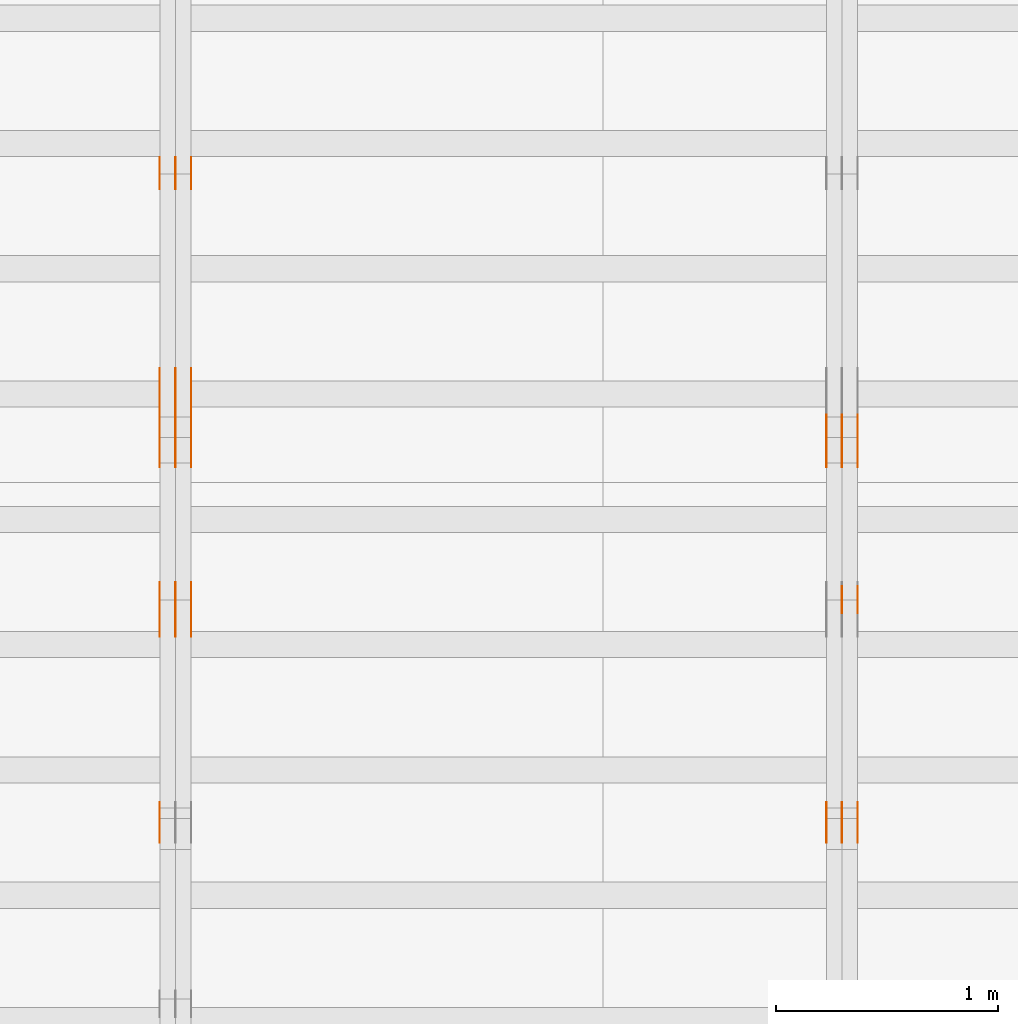
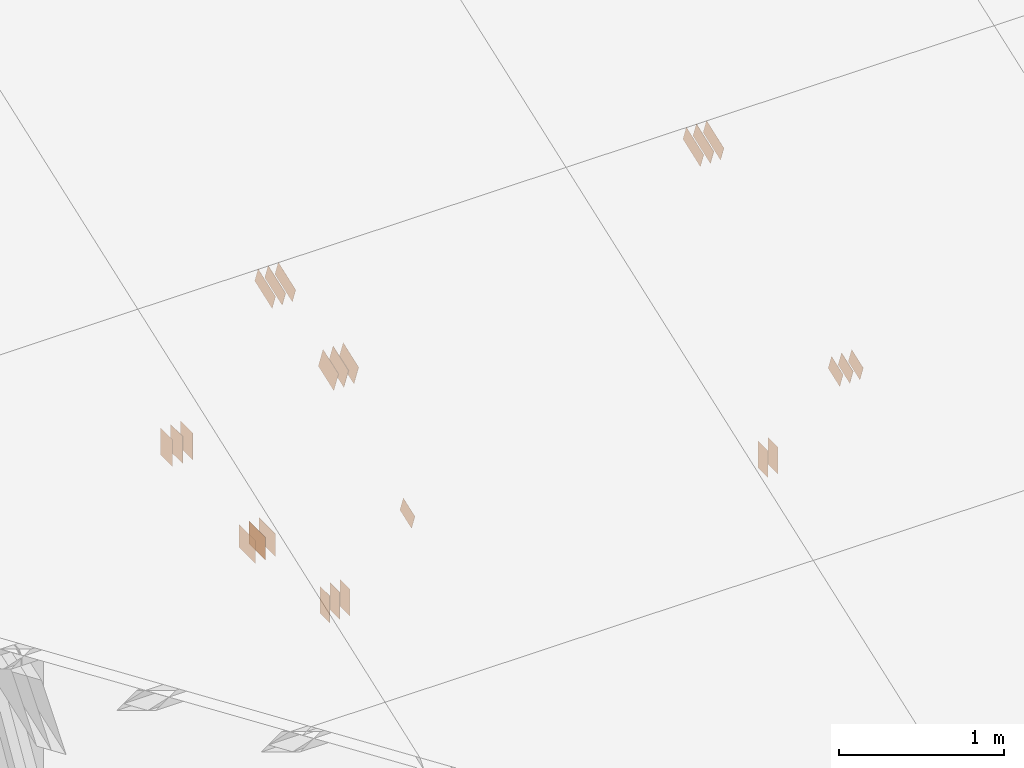
# One storey, part 138 of 189: 31 proxies.
"""IFC2X3 building model written with IfcOpenShell, lengths in millimetres."""

from ifc_helpers import new_model, entity, si_unit, converted_unit, derived_unit, direction, frame, frame_2d, origin, origin_2d_with_axis, place, context, subcontext, project, spatial, polyline, rectangle, outline, extrude, source, transform, mapped, material, type_object, type_shapes, element, save


model = new_model("IFC2X3")

# Units and contexts
model_context = context("Model", 3, precision=0.01, world=origin(), true_north=direction((6.12303176911189e-17, 1.0)))
body_context = subcontext(model_context, "Body", "Model", "MODEL_VIEW")
ifc_project = project(units=[si_unit("LENGTHUNIT", "METRE", prefix="MILLI"), si_unit("AREAUNIT", "SQUARE_METRE"), si_unit("VOLUMEUNIT", "CUBIC_METRE"), converted_unit("PLANEANGLEUNIT", "DEGREE", entity("IfcRatioMeasure", 0.0174532925199433), si_unit("PLANEANGLEUNIT", "RADIAN"), dimensions=[0, 0, 0, 0, 0, 0, 0]), si_unit("MASSUNIT", "GRAM", prefix="KILO"), derived_unit("MASSDENSITYUNIT", [(si_unit("MASSUNIT", "GRAM", prefix="KILO"), 1), (si_unit("LENGTHUNIT", "METRE"), -3)]), si_unit("TIMEUNIT", "SECOND"), si_unit("FREQUENCYUNIT", "HERTZ"), si_unit("THERMODYNAMICTEMPERATUREUNIT", "DEGREE_CELSIUS"), derived_unit("THERMALTRANSMITTANCEUNIT", [(si_unit("MASSUNIT", "GRAM", prefix="KILO"), 1), (si_unit("THERMODYNAMICTEMPERATUREUNIT", "KELVIN"), -1), (si_unit("TIMEUNIT", "SECOND"), -3)]), derived_unit("VOLUMETRICFLOWRATEUNIT", [(si_unit("LENGTHUNIT", "METRE"), 3), (si_unit("TIMEUNIT", "SECOND"), -1)]), si_unit("ELECTRICCURRENTUNIT", "AMPERE"), si_unit("ELECTRICVOLTAGEUNIT", "VOLT"), si_unit("POWERUNIT", "WATT"), si_unit("FORCEUNIT", "NEWTON"), si_unit("ILLUMINANCEUNIT", "LUX"), si_unit("LUMINOUSFLUXUNIT", "LUMEN"), si_unit("LUMINOUSINTENSITYUNIT", "CANDELA"), derived_unit("USERDEFINED", [(si_unit("MASSUNIT", "GRAM", prefix="KILO"), -1), (si_unit("LENGTHUNIT", "METRE"), -2), (si_unit("TIMEUNIT", "SECOND"), 3), (si_unit("LUMINOUSFLUXUNIT", "LUMEN"), 1)]), derived_unit("LINEARVELOCITYUNIT", [(si_unit("LENGTHUNIT", "METRE"), 1), (si_unit("TIMEUNIT", "SECOND"), -1)]), si_unit("PRESSUREUNIT", "PASCAL"), derived_unit("USERDEFINED", [(si_unit("LENGTHUNIT", "METRE"), -2), (si_unit("MASSUNIT", "GRAM", prefix="KILO"), 1), (si_unit("TIMEUNIT", "SECOND"), -2)])], contexts=[model_context])

# Site, building, storey
site_placement = place(None, origin())
site = spatial("IfcSite", under=ifc_project, at=site_placement, CompositionType="ELEMENT")
building_placement = place(site_placement, origin())
building = spatial("IfcBuilding", under=site, at=building_placement, CompositionType="ELEMENT")
storey_placement = place(building_placement, origin())
storey = spatial("IfcBuildingStorey", under=building, at=storey_placement, Name="Default", CompositionType="ELEMENT", Elevation=0.0)

# Proxies
ifc_material_1 = material(Name="IfcSurfaceStyle #201446")
building_element_proxy_type_1 = type_object("IfcBuildingElementProxyType", PredefinedType="NOTDEFINED", material=ifc_material_1)
shared_shape_1 = source(origin(), body_context, "Body", "SweptSolid", [
    extrude(outline(polyline([(-112.500654374667, -59.9999021691247), (112.500117969231, -59.9999021691247), (112.500612624162, 59.9999021691247), (-112.500076218726, 59.9999021691247), (-112.500654374667, -59.9999021691247)])), frame((112.500612624162, 60.0003514046321, 0.0), z_axis=(0.0, 0.0, 1.0), x_axis=(-1.0, 0.0, 0.0)), (0.0, 0.0, 1.0), 1.3),
])
type_shapes(building_element_proxy_type_1, [shared_shape_1])
proxy_1_placement = place(building_placement, frame((36301.3, 5418.0703125, 2162.37353515625), z_axis=(-1.0, 0.0, 0.0), x_axis=(0.0, 0.939692620785908, 0.342020143325669)))
element("IfcBuildingElementProxy", 1, at=proxy_1_placement, inside=storey, type_object=building_element_proxy_type_1, material=ifc_material_1, context=body_context, shape_type="MappedRepresentation", body=[
    mapped(shared_shape_1, transform((0.0, 0.0, 0.0), scale=1.0)),
])
ifc_material_2 = material(Name="IfcSurfaceStyle #201389")
building_element_proxy_type_2 = type_object("IfcBuildingElementProxyType", PredefinedType="NOTDEFINED", material=ifc_material_2)
shared_shape_2 = source(origin(), body_context, "Body", "SweptSolid", [
    extrude(outline(polyline([(-112.500654374667, -59.9999021691247), (112.500117969231, -59.9999021691247), (112.500612624162, 59.9999021691247), (-112.500076218726, 59.9999021691247), (-112.500654374667, -59.9999021691247)])), frame((112.500612624162, 60.0003514046321, 0.0), z_axis=(0.0, 0.0, 1.0), x_axis=(-1.0, 0.0, 0.0)), (0.0, 0.0, 1.0), 1.29999999999998),
])
type_shapes(building_element_proxy_type_2, [shared_shape_2])
proxy_2_placement = place(building_placement, frame((36230.0, 5418.0703125, 2162.37353515625), z_axis=(-1.0, 0.0, 0.0), x_axis=(0.0, 0.939692620785908, 0.342020143325669)))
element("IfcBuildingElementProxy", 2, at=proxy_2_placement, inside=storey, type_object=building_element_proxy_type_2, material=ifc_material_2, context=body_context, shape_type="MappedRepresentation", body=[
    mapped(shared_shape_2, transform((0.0, 0.0, 0.0), scale=1.0)),
])
ifc_material_3 = material(Name="IfcSurfaceStyle #201332")
building_element_proxy_type_3 = type_object("IfcBuildingElementProxyType", PredefinedType="NOTDEFINED", material=ifc_material_3)
shared_shape_3 = source(origin(), body_context, "Body", "SweptSolid", [
    extrude(outline(polyline([(-112.500654374667, -59.9999021691247), (112.500117969231, -59.9999021691247), (112.500612624162, 59.9999021691247), (-112.500076218726, 59.9999021691247), (-112.500654374667, -59.9999021691247)])), frame((112.500612624162, 60.0003514046321, 0.0), z_axis=(0.0, 0.0, 1.0), x_axis=(-1.0, 0.0, 0.0)), (0.0, 0.0, 1.0), 1.29999999999998),
])
type_shapes(building_element_proxy_type_3, [shared_shape_3])
proxy_3_placement = place(building_placement, frame((36231.3, 5418.0703125, 2162.37353515625), z_axis=(-1.0, 0.0, 0.0), x_axis=(0.0, 0.939692620785908, 0.342020143325669)))
element("IfcBuildingElementProxy", 3, at=proxy_3_placement, inside=storey, type_object=building_element_proxy_type_3, material=ifc_material_3, context=body_context, shape_type="MappedRepresentation", body=[
    mapped(shared_shape_3, transform((0.0, 0.0, 0.0), scale=1.0)),
])
ifc_material_4 = material(Name="IfcSurfaceStyle #201275")
building_element_proxy_type_4 = type_object("IfcBuildingElementProxyType", PredefinedType="NOTDEFINED", material=ifc_material_4)
shared_shape_4 = source(origin(), body_context, "Body", "SweptSolid", [
    extrude(outline(polyline([(-112.500654374667, -59.9999021691247), (112.500117969231, -59.9999021691247), (112.500612624162, 59.9999021691247), (-112.500076218726, 59.9999021691247), (-112.500654374667, -59.9999021691247)])), frame((112.500612624162, 60.0003514046321, 0.0), z_axis=(0.0, 0.0, 1.0), x_axis=(-1.0, 0.0, 0.0)), (0.0, 0.0, 1.0), 1.29999999999999),
])
type_shapes(building_element_proxy_type_4, [shared_shape_4])
proxy_4_placement = place(building_placement, frame((36160.0, 5418.0703125, 2162.37353515625), z_axis=(-1.0, 0.0, 0.0), x_axis=(0.0, 0.939692620785908, 0.342020143325669)))
element("IfcBuildingElementProxy", 4, at=proxy_4_placement, inside=storey, type_object=building_element_proxy_type_4, material=ifc_material_4, context=body_context, shape_type="MappedRepresentation", body=[
    mapped(shared_shape_4, transform((0.0, 0.0, 0.0), scale=1.0)),
])
ifc_material_5 = material(Name="IfcSurfaceStyle #200762")
building_element_proxy_type_5 = type_object("IfcBuildingElementProxyType", PredefinedType="NOTDEFINED", material=ifc_material_5)
shared_shape_5 = source(origin(), body_context, "Body", "SweptSolid", [
    extrude(rectangle(XDim=200.0, YDim=120.0, at=origin_2d_with_axis()), frame((100.0, 60.0, 0.0), z_axis=(0.0, 0.0, 1.0), x_axis=(-1.0, 0.0, 0.0)), (0.0, 0.0, 1.0), 1.3),
])
type_shapes(building_element_proxy_type_5, [shared_shape_5])
proxy_5_placement = place(building_placement, frame((36301.3, 4760.65625, 145.0), z_axis=(-1.0, 0.0, 0.0), x_axis=(0.0, 0.0, 1.0)))
element("IfcBuildingElementProxy", 5, at=proxy_5_placement, inside=storey, type_object=building_element_proxy_type_5, material=ifc_material_5, context=body_context, shape_type="MappedRepresentation", body=[
    mapped(shared_shape_5, transform((0.0, 0.0, 0.0), scale=1.0)),
])
ifc_material_6 = material(Name="IfcSurfaceStyle #200705")
building_element_proxy_type_6 = type_object("IfcBuildingElementProxyType", PredefinedType="NOTDEFINED", material=ifc_material_6)
shared_shape_6 = source(origin(), body_context, "Body", "SweptSolid", [
    extrude(rectangle(XDim=200.0, YDim=120.0, at=origin_2d_with_axis()), frame((100.0, 60.0, 0.0), z_axis=(0.0, 0.0, 1.0), x_axis=(-1.0, 0.0, 0.0)), (0.0, 0.0, 1.0), 1.29999999999998),
])
type_shapes(building_element_proxy_type_6, [shared_shape_6])
proxy_6_placement = place(building_placement, frame((36230.0, 4760.65625, 145.0), z_axis=(-1.0, 0.0, 0.0), x_axis=(0.0, 0.0, 1.0)))
element("IfcBuildingElementProxy", 6, at=proxy_6_placement, inside=storey, type_object=building_element_proxy_type_6, material=ifc_material_6, context=body_context, shape_type="MappedRepresentation", body=[
    mapped(shared_shape_6, transform((0.0, 0.0, 0.0), scale=1.0)),
])
ifc_material_7 = material(Name="IfcSurfaceStyle #200534")
building_element_proxy_type_7 = type_object("IfcBuildingElementProxyType", PredefinedType="NOTDEFINED", material=ifc_material_7)
shared_shape_7 = source(origin(), body_context, "Body", "SweptSolid", [
    extrude(outline(polyline([(-74.9994515581384, -59.9999039432178), (74.9998536965286, -59.9999039432178), (75.0003483514593, 59.9999039432178), (-75.0007504898495, 59.9999039432178), (-74.9994515581384, -59.9999039432178)])), frame((75.0003483514593, 60.0003496305408, 0.0), z_axis=(0.0, 0.0, 1.0), x_axis=(-1.0, 0.0, 0.0)), (0.0, 0.0, 1.0), 1.3),
])
type_shapes(building_element_proxy_type_7, [shared_shape_7])
proxy_7_placement = place(building_placement, frame((36301.3, 3726.8984375, 1559.607421875), z_axis=(-1.0, 0.0, 0.0), x_axis=(0.0, 0.939692620785908, 0.342020143325669)))
element("IfcBuildingElementProxy", 7, at=proxy_7_placement, inside=storey, type_object=building_element_proxy_type_7, material=ifc_material_7, context=body_context, shape_type="MappedRepresentation", body=[
    mapped(shared_shape_7, transform((0.0, 0.0, 0.0), scale=1.0)),
])
ifc_material_8 = material(Name="IfcSurfaceStyle #200477")
building_element_proxy_type_8 = type_object("IfcBuildingElementProxyType", PredefinedType="NOTDEFINED", material=ifc_material_8)
shared_shape_8 = source(origin(), body_context, "Body", "SweptSolid", [
    extrude(outline(polyline([(-74.9994515581384, -59.9999039432178), (74.9998536965286, -59.9999039432178), (75.0003483514593, 59.9999039432178), (-75.0007504898495, 59.9999039432178), (-74.9994515581384, -59.9999039432178)])), frame((75.0003483514593, 60.0003496305408, 0.0), z_axis=(0.0, 0.0, 1.0), x_axis=(-1.0, 0.0, 0.0)), (0.0, 0.0, 1.0), 1.29999999999999),
])
type_shapes(building_element_proxy_type_8, [shared_shape_8])
proxy_8_placement = place(building_placement, frame((36230.0, 3726.8984375, 1559.607421875), z_axis=(-1.0, 0.0, 0.0), x_axis=(0.0, 0.939692620785908, 0.342020143325669)))
element("IfcBuildingElementProxy", 8, at=proxy_8_placement, inside=storey, type_object=building_element_proxy_type_8, material=ifc_material_8, context=body_context, shape_type="MappedRepresentation", body=[
    mapped(shared_shape_8, transform((0.0, 0.0, 0.0), scale=1.0)),
])
ifc_material_9 = material(Name="IfcSurfaceStyle #200420")
building_element_proxy_type_9 = type_object("IfcBuildingElementProxyType", PredefinedType="NOTDEFINED", material=ifc_material_9)
shared_shape_9 = source(origin(), body_context, "Body", "SweptSolid", [
    extrude(outline(polyline([(-74.9994515581384, -59.9999039432178), (74.9998536965286, -59.9999039432178), (75.0003483514593, 59.9999039432178), (-75.0007504898495, 59.9999039432178), (-74.9994515581384, -59.9999039432178)])), frame((75.0003483514593, 60.0003496305408, 0.0), z_axis=(0.0, 0.0, 1.0), x_axis=(-1.0, 0.0, 0.0)), (0.0, 0.0, 1.0), 1.29999999999999),
])
type_shapes(building_element_proxy_type_9, [shared_shape_9])
proxy_9_placement = place(building_placement, frame((36231.3, 3726.8984375, 1559.607421875), z_axis=(-1.0, 0.0, 0.0), x_axis=(0.0, 0.939692620785908, 0.342020143325669)))
element("IfcBuildingElementProxy", 9, at=proxy_9_placement, inside=storey, type_object=building_element_proxy_type_9, material=ifc_material_9, context=body_context, shape_type="MappedRepresentation", body=[
    mapped(shared_shape_9, transform((0.0, 0.0, 0.0), scale=1.0)),
])
ifc_material_10 = material(Name="IfcSurfaceStyle #200363")
building_element_proxy_type_10 = type_object("IfcBuildingElementProxyType", PredefinedType="NOTDEFINED", material=ifc_material_10)
shared_shape_10 = source(origin(), body_context, "Body", "SweptSolid", [
    extrude(outline(polyline([(-74.9994515581384, -59.9999039432178), (74.9998536965286, -59.9999039432178), (75.0003483514593, 59.9999039432178), (-75.0007504898495, 59.9999039432178), (-74.9994515581384, -59.9999039432178)])), frame((75.0003483514593, 60.0003496305408, 0.0), z_axis=(0.0, 0.0, 1.0), x_axis=(-1.0, 0.0, 0.0)), (0.0, 0.0, 1.0), 1.29999999999999),
])
type_shapes(building_element_proxy_type_10, [shared_shape_10])
proxy_10_placement = place(building_placement, frame((36160.0, 3726.8984375, 1559.607421875), z_axis=(-1.0, 0.0, 0.0), x_axis=(0.0, 0.939692620785908, 0.342020143325669)))
element("IfcBuildingElementProxy", 10, at=proxy_10_placement, inside=storey, type_object=building_element_proxy_type_10, material=ifc_material_10, context=body_context, shape_type="MappedRepresentation", body=[
    mapped(shared_shape_10, transform((0.0, 0.0, 0.0), scale=1.0)),
])
ifc_material_11 = material(Name="IfcSurfaceStyle #189532")
building_element_proxy_type_11 = type_object("IfcBuildingElementProxyType", PredefinedType="NOTDEFINED", material=ifc_material_11)
shared_shape_11 = source(origin(), body_context, "Body", "SweptSolid", [
    extrude(rectangle(XDim=200.0, YDim=144.0, at=frame_2d((1.4210854715202e-14, 0.0), x_axis=(1.0, 0.0))), frame((100.0, 72.0, 0.0), z_axis=(0.0, 0.0, 1.0), x_axis=(-1.0, 0.0, 0.0)), (0.0, 0.0, 1.0), 1.3),
])
type_shapes(building_element_proxy_type_11, [shared_shape_11])
proxy_11_placement = place(building_placement, frame((33301.3, 6668.833984375, 145.0), z_axis=(-1.0, 0.0, 0.0), x_axis=(0.0, 0.0, 1.0)))
element("IfcBuildingElementProxy", 11, at=proxy_11_placement, inside=storey, type_object=building_element_proxy_type_11, material=ifc_material_11, context=body_context, shape_type="MappedRepresentation", body=[
    mapped(shared_shape_11, transform((0.0, 0.0, 0.0), scale=1.0)),
])
ifc_material_12 = material(Name="IfcSurfaceStyle #189475")
building_element_proxy_type_12 = type_object("IfcBuildingElementProxyType", PredefinedType="NOTDEFINED", material=ifc_material_12)
shared_shape_12 = source(origin(), body_context, "Body", "SweptSolid", [
    extrude(rectangle(XDim=200.0, YDim=144.0, at=frame_2d((1.4210854715202e-14, 0.0), x_axis=(1.0, 0.0))), frame((100.0, 72.0, 0.0), z_axis=(0.0, 0.0, 1.0), x_axis=(-1.0, 0.0, 0.0)), (0.0, 0.0, 1.0), 1.29999999999998),
])
type_shapes(building_element_proxy_type_12, [shared_shape_12])
proxy_12_placement = place(building_placement, frame((33230.0, 6668.833984375, 145.0), z_axis=(-1.0, 0.0, 0.0), x_axis=(0.0, 0.0, 1.0)))
element("IfcBuildingElementProxy", 12, at=proxy_12_placement, inside=storey, type_object=building_element_proxy_type_12, material=ifc_material_12, context=body_context, shape_type="MappedRepresentation", body=[
    mapped(shared_shape_12, transform((0.0, 0.0, 0.0), scale=1.0)),
])
ifc_material_13 = material(Name="IfcSurfaceStyle #189418")
building_element_proxy_type_13 = type_object("IfcBuildingElementProxyType", PredefinedType="NOTDEFINED", material=ifc_material_13)
shared_shape_13 = source(origin(), body_context, "Body", "SweptSolid", [
    extrude(rectangle(XDim=200.0, YDim=144.0, at=frame_2d((1.4210854715202e-14, 0.0), x_axis=(1.0, 0.0))), frame((100.0, 72.0, 0.0), z_axis=(0.0, 0.0, 1.0), x_axis=(-1.0, 0.0, 0.0)), (0.0, 0.0, 1.0), 1.29999999999998),
])
type_shapes(building_element_proxy_type_13, [shared_shape_13])
proxy_13_placement = place(building_placement, frame((33231.3, 6668.833984375, 145.0), z_axis=(-1.0, 0.0, 0.0), x_axis=(0.0, 0.0, 1.0)))
element("IfcBuildingElementProxy", 13, at=proxy_13_placement, inside=storey, type_object=building_element_proxy_type_13, material=ifc_material_13, context=body_context, shape_type="MappedRepresentation", body=[
    mapped(shared_shape_13, transform((0.0, 0.0, 0.0), scale=1.0)),
])
ifc_material_14 = material(Name="IfcSurfaceStyle #189361")
building_element_proxy_type_14 = type_object("IfcBuildingElementProxyType", PredefinedType="NOTDEFINED", material=ifc_material_14)
shared_shape_14 = source(origin(), body_context, "Body", "SweptSolid", [
    extrude(rectangle(XDim=200.0, YDim=144.0, at=frame_2d((1.4210854715202e-14, 0.0), x_axis=(1.0, 0.0))), frame((100.0, 72.0, 0.0), z_axis=(0.0, 0.0, 1.0), x_axis=(-1.0, 0.0, 0.0)), (0.0, 0.0, 1.0), 1.29999999999999),
])
type_shapes(building_element_proxy_type_14, [shared_shape_14])
proxy_14_placement = place(building_placement, frame((33160.0, 6668.833984375, 145.0), z_axis=(-1.0, 0.0, 0.0), x_axis=(0.0, 0.0, 1.0)))
element("IfcBuildingElementProxy", 14, at=proxy_14_placement, inside=storey, type_object=building_element_proxy_type_14, material=ifc_material_14, context=body_context, shape_type="MappedRepresentation", body=[
    mapped(shared_shape_14, transform((0.0, 0.0, 0.0), scale=1.0)),
])
ifc_material_15 = material(Name="IfcSurfaceStyle #189304")
building_element_proxy_type_15 = type_object("IfcBuildingElementProxyType", PredefinedType="NOTDEFINED", material=ifc_material_15)
shared_shape_15 = source(origin(), body_context, "Body", "SweptSolid", [
    extrude(rectangle(XDim=200.0, YDim=168.0, at=origin_2d_with_axis()), frame((100.0, 84.0, 0.0), z_axis=(0.0, 0.0, 1.0), x_axis=(-1.0, 0.0, 0.0)), (0.0, 0.0, 1.0), 1.3),
])
type_shapes(building_element_proxy_type_15, [shared_shape_15])
proxy_15_placement = place(building_placement, frame((33301.3, 5662.466796875, 206.5), z_axis=(-1.0, 0.0, 0.0), x_axis=(0.0, 1.0, 0.0)))
element("IfcBuildingElementProxy", 15, at=proxy_15_placement, inside=storey, type_object=building_element_proxy_type_15, material=ifc_material_15, context=body_context, shape_type="MappedRepresentation", body=[
    mapped(shared_shape_15, transform((0.0, 0.0, 0.0), scale=1.0)),
])
ifc_material_16 = material(Name="IfcSurfaceStyle #189247")
building_element_proxy_type_16 = type_object("IfcBuildingElementProxyType", PredefinedType="NOTDEFINED", material=ifc_material_16)
shared_shape_16 = source(origin(), body_context, "Body", "SweptSolid", [
    extrude(rectangle(XDim=200.0, YDim=168.0, at=origin_2d_with_axis()), frame((100.0, 84.0, 0.0), z_axis=(0.0, 0.0, 1.0), x_axis=(-1.0, 0.0, 0.0)), (0.0, 0.0, 1.0), 1.29999999999998),
])
type_shapes(building_element_proxy_type_16, [shared_shape_16])
proxy_16_placement = place(building_placement, frame((33230.0, 5662.466796875, 206.5), z_axis=(-1.0, 0.0, 0.0), x_axis=(0.0, 1.0, 0.0)))
element("IfcBuildingElementProxy", 16, at=proxy_16_placement, inside=storey, type_object=building_element_proxy_type_16, material=ifc_material_16, context=body_context, shape_type="MappedRepresentation", body=[
    mapped(shared_shape_16, transform((0.0, 0.0, 0.0), scale=1.0)),
])
ifc_material_17 = material(Name="IfcSurfaceStyle #189190")
building_element_proxy_type_17 = type_object("IfcBuildingElementProxyType", PredefinedType="NOTDEFINED", material=ifc_material_17)
shared_shape_17 = source(origin(), body_context, "Body", "SweptSolid", [
    extrude(rectangle(XDim=200.0, YDim=168.0, at=origin_2d_with_axis()), frame((100.0, 84.0, 0.0), z_axis=(0.0, 0.0, 1.0), x_axis=(-1.0, 0.0, 0.0)), (0.0, 0.0, 1.0), 1.29999999999998),
])
type_shapes(building_element_proxy_type_17, [shared_shape_17])
proxy_17_placement = place(building_placement, frame((33231.3, 5662.466796875, 206.5), z_axis=(-1.0, 0.0, 0.0), x_axis=(0.0, 1.0, 0.0)))
element("IfcBuildingElementProxy", 17, at=proxy_17_placement, inside=storey, type_object=building_element_proxy_type_17, material=ifc_material_17, context=body_context, shape_type="MappedRepresentation", body=[
    mapped(shared_shape_17, transform((0.0, 0.0, 0.0), scale=1.0)),
])
ifc_material_18 = material(Name="IfcSurfaceStyle #189133")
building_element_proxy_type_18 = type_object("IfcBuildingElementProxyType", PredefinedType="NOTDEFINED", material=ifc_material_18)
shared_shape_18 = source(origin(), body_context, "Body", "SweptSolid", [
    extrude(rectangle(XDim=200.0, YDim=168.0, at=origin_2d_with_axis()), frame((100.0, 84.0, 0.0), z_axis=(0.0, 0.0, 1.0), x_axis=(-1.0, 0.0, 0.0)), (0.0, 0.0, 1.0), 1.29999999999999),
])
type_shapes(building_element_proxy_type_18, [shared_shape_18])
proxy_18_placement = place(building_placement, frame((33160.0, 5662.466796875, 206.5), z_axis=(-1.0, 0.0, 0.0), x_axis=(0.0, 1.0, 0.0)))
element("IfcBuildingElementProxy", 18, at=proxy_18_placement, inside=storey, type_object=building_element_proxy_type_18, material=ifc_material_18, context=body_context, shape_type="MappedRepresentation", body=[
    mapped(shared_shape_18, transform((0.0, 0.0, 0.0), scale=1.0)),
])
ifc_material_19 = material(Name="IfcSurfaceStyle #185656")
building_element_proxy_type_19 = type_object("IfcBuildingElementProxyType", PredefinedType="NOTDEFINED", material=ifc_material_19)
shared_shape_19 = source(origin(), body_context, "Body", "SweptSolid", [
    extrude(outline(polyline([(-112.500654374667, -59.9999021691247), (112.500117969231, -59.9999021691247), (112.500612624162, 59.9999021691247), (-112.500076218726, 59.9999021691247), (-112.500654374667, -59.9999021691247)])), frame((112.500612624162, 60.0003514046321, 0.0), z_axis=(0.0, 0.0, 1.0), x_axis=(-1.0, 0.0, 0.0)), (0.0, 0.0, 1.0), 1.3),
])
type_shapes(building_element_proxy_type_19, [shared_shape_19])
proxy_19_placement = place(building_placement, frame((33301.3, 5418.0703125, 2162.37353515625), z_axis=(-1.0, 0.0, 0.0), x_axis=(0.0, 0.939692620785908, 0.342020143325669)))
element("IfcBuildingElementProxy", 19, at=proxy_19_placement, inside=storey, type_object=building_element_proxy_type_19, material=ifc_material_19, context=body_context, shape_type="MappedRepresentation", body=[
    mapped(shared_shape_19, transform((0.0, 0.0, 0.0), scale=1.0)),
])
ifc_material_20 = material(Name="IfcSurfaceStyle #185599")
building_element_proxy_type_20 = type_object("IfcBuildingElementProxyType", PredefinedType="NOTDEFINED", material=ifc_material_20)
shared_shape_20 = source(origin(), body_context, "Body", "SweptSolid", [
    extrude(outline(polyline([(-112.500654374667, -59.9999021691247), (112.500117969231, -59.9999021691247), (112.500612624162, 59.9999021691247), (-112.500076218726, 59.9999021691247), (-112.500654374667, -59.9999021691247)])), frame((112.500612624162, 60.0003514046321, 0.0), z_axis=(0.0, 0.0, 1.0), x_axis=(-1.0, 0.0, 0.0)), (0.0, 0.0, 1.0), 1.29999999999998),
])
type_shapes(building_element_proxy_type_20, [shared_shape_20])
proxy_20_placement = place(building_placement, frame((33230.0, 5418.0703125, 2162.37353515625), z_axis=(-1.0, 0.0, 0.0), x_axis=(0.0, 0.939692620785908, 0.342020143325669)))
element("IfcBuildingElementProxy", 20, at=proxy_20_placement, inside=storey, type_object=building_element_proxy_type_20, material=ifc_material_20, context=body_context, shape_type="MappedRepresentation", body=[
    mapped(shared_shape_20, transform((0.0, 0.0, 0.0), scale=1.0)),
])
ifc_material_21 = material(Name="IfcSurfaceStyle #185542")
building_element_proxy_type_21 = type_object("IfcBuildingElementProxyType", PredefinedType="NOTDEFINED", material=ifc_material_21)
shared_shape_21 = source(origin(), body_context, "Body", "SweptSolid", [
    extrude(outline(polyline([(-112.500654374667, -59.9999021691247), (112.500117969231, -59.9999021691247), (112.500612624162, 59.9999021691247), (-112.500076218726, 59.9999021691247), (-112.500654374667, -59.9999021691247)])), frame((112.500612624162, 60.0003514046321, 0.0), z_axis=(0.0, 0.0, 1.0), x_axis=(-1.0, 0.0, 0.0)), (0.0, 0.0, 1.0), 1.29999999999998),
])
type_shapes(building_element_proxy_type_21, [shared_shape_21])
proxy_21_placement = place(building_placement, frame((33231.3, 5418.0703125, 2162.37353515625), z_axis=(-1.0, 0.0, 0.0), x_axis=(0.0, 0.939692620785908, 0.342020143325669)))
element("IfcBuildingElementProxy", 21, at=proxy_21_placement, inside=storey, type_object=building_element_proxy_type_21, material=ifc_material_21, context=body_context, shape_type="MappedRepresentation", body=[
    mapped(shared_shape_21, transform((0.0, 0.0, 0.0), scale=1.0)),
])
ifc_material_22 = material(Name="IfcSurfaceStyle #185485")
building_element_proxy_type_22 = type_object("IfcBuildingElementProxyType", PredefinedType="NOTDEFINED", material=ifc_material_22)
shared_shape_22 = source(origin(), body_context, "Body", "SweptSolid", [
    extrude(outline(polyline([(-112.500654374667, -59.9999021691247), (112.500117969231, -59.9999021691247), (112.500612624162, 59.9999021691247), (-112.500076218726, 59.9999021691247), (-112.500654374667, -59.9999021691247)])), frame((112.500612624162, 60.0003514046321, 0.0), z_axis=(0.0, 0.0, 1.0), x_axis=(-1.0, 0.0, 0.0)), (0.0, 0.0, 1.0), 1.29999999999999),
])
type_shapes(building_element_proxy_type_22, [shared_shape_22])
proxy_22_placement = place(building_placement, frame((33160.0, 5418.0703125, 2162.37353515625), z_axis=(-1.0, 0.0, 0.0), x_axis=(0.0, 0.939692620785908, 0.342020143325669)))
element("IfcBuildingElementProxy", 22, at=proxy_22_placement, inside=storey, type_object=building_element_proxy_type_22, material=ifc_material_22, context=body_context, shape_type="MappedRepresentation", body=[
    mapped(shared_shape_22, transform((0.0, 0.0, 0.0), scale=1.0)),
])
ifc_material_23 = material(Name="IfcSurfaceStyle #184972")
building_element_proxy_type_23 = type_object("IfcBuildingElementProxyType", PredefinedType="NOTDEFINED", material=ifc_material_23)
shared_shape_23 = source(origin(), body_context, "Body", "SweptSolid", [
    extrude(rectangle(XDim=200.0, YDim=120.0, at=origin_2d_with_axis()), frame((100.0, 60.0, 0.0), z_axis=(0.0, 0.0, 1.0), x_axis=(-1.0, 0.0, 0.0)), (0.0, 0.0, 1.0), 1.3),
])
type_shapes(building_element_proxy_type_23, [shared_shape_23])
proxy_23_placement = place(building_placement, frame((33301.3, 4760.65625, 145.0), z_axis=(-1.0, 0.0, 0.0), x_axis=(0.0, 0.0, 1.0)))
element("IfcBuildingElementProxy", 23, at=proxy_23_placement, inside=storey, type_object=building_element_proxy_type_23, material=ifc_material_23, context=body_context, shape_type="MappedRepresentation", body=[
    mapped(shared_shape_23, transform((0.0, 0.0, 0.0), scale=1.0)),
])
ifc_material_24 = material(Name="IfcSurfaceStyle #184915")
building_element_proxy_type_24 = type_object("IfcBuildingElementProxyType", PredefinedType="NOTDEFINED", material=ifc_material_24)
shared_shape_24 = source(origin(), body_context, "Body", "SweptSolid", [
    extrude(rectangle(XDim=200.0, YDim=120.0, at=origin_2d_with_axis()), frame((100.0, 60.0, 0.0), z_axis=(0.0, 0.0, 1.0), x_axis=(-1.0, 0.0, 0.0)), (0.0, 0.0, 1.0), 1.29999999999998),
])
type_shapes(building_element_proxy_type_24, [shared_shape_24])
proxy_24_placement = place(building_placement, frame((33230.0, 4760.65625, 145.0), z_axis=(-1.0, 0.0, 0.0), x_axis=(0.0, 0.0, 1.0)))
element("IfcBuildingElementProxy", 24, at=proxy_24_placement, inside=storey, type_object=building_element_proxy_type_24, material=ifc_material_24, context=body_context, shape_type="MappedRepresentation", body=[
    mapped(shared_shape_24, transform((0.0, 0.0, 0.0), scale=1.0)),
])
ifc_material_25 = material(Name="IfcSurfaceStyle #184858")
building_element_proxy_type_25 = type_object("IfcBuildingElementProxyType", PredefinedType="NOTDEFINED", material=ifc_material_25)
shared_shape_25 = source(origin(), body_context, "Body", "SweptSolid", [
    extrude(rectangle(XDim=200.0, YDim=120.0, at=origin_2d_with_axis()), frame((100.0, 60.0, 0.0), z_axis=(0.0, 0.0, 1.0), x_axis=(-1.0, 0.0, 0.0)), (0.0, 0.0, 1.0), 1.29999999999998),
])
type_shapes(building_element_proxy_type_25, [shared_shape_25])
proxy_25_placement = place(building_placement, frame((33231.3, 4760.65625, 145.0), z_axis=(-1.0, 0.0, 0.0), x_axis=(0.0, 0.0, 1.0)))
element("IfcBuildingElementProxy", 25, at=proxy_25_placement, inside=storey, type_object=building_element_proxy_type_25, material=ifc_material_25, context=body_context, shape_type="MappedRepresentation", body=[
    mapped(shared_shape_25, transform((0.0, 0.0, 0.0), scale=1.0)),
])
ifc_material_26 = material(Name="IfcSurfaceStyle #184801")
building_element_proxy_type_26 = type_object("IfcBuildingElementProxyType", PredefinedType="NOTDEFINED", material=ifc_material_26)
shared_shape_26 = source(origin(), body_context, "Body", "SweptSolid", [
    extrude(rectangle(XDim=200.0, YDim=120.0, at=origin_2d_with_axis()), frame((100.0, 60.0, 0.0), z_axis=(0.0, 0.0, 1.0), x_axis=(-1.0, 0.0, 0.0)), (0.0, 0.0, 1.0), 1.29999999999999),
])
type_shapes(building_element_proxy_type_26, [shared_shape_26])
proxy_26_placement = place(building_placement, frame((33160.0, 4760.65625, 145.0), z_axis=(-1.0, 0.0, 0.0), x_axis=(0.0, 0.0, 1.0)))
element("IfcBuildingElementProxy", 26, at=proxy_26_placement, inside=storey, type_object=building_element_proxy_type_26, material=ifc_material_26, context=body_context, shape_type="MappedRepresentation", body=[
    mapped(shared_shape_26, transform((0.0, 0.0, 0.0), scale=1.0)),
])
ifc_material_27 = material(Name="IfcSurfaceStyle #184573")
building_element_proxy_type_27 = type_object("IfcBuildingElementProxyType", PredefinedType="NOTDEFINED", material=ifc_material_27)
shared_shape_27 = source(origin(), body_context, "Body", "SweptSolid", [
    extrude(outline(polyline([(-74.9994515581384, -59.9999039432178), (74.9998536965286, -59.9999039432178), (75.0003483514593, 59.9999039432178), (-75.0007504898495, 59.9999039432178), (-74.9994515581384, -59.9999039432178)])), frame((75.0003483514593, 60.0003496305408, 0.0), z_axis=(0.0, 0.0, 1.0), x_axis=(-1.0, 0.0, 0.0)), (0.0, 0.0, 1.0), 1.29999999999999),
])
type_shapes(building_element_proxy_type_27, [shared_shape_27])
proxy_27_placement = place(building_placement, frame((33160.0, 3726.8984375, 1559.607421875), z_axis=(-1.0, 0.0, 0.0), x_axis=(0.0, 0.939692620785908, 0.342020143325669)))
element("IfcBuildingElementProxy", 27, at=proxy_27_placement, inside=storey, type_object=building_element_proxy_type_27, material=ifc_material_27, context=body_context, shape_type="MappedRepresentation", body=[
    mapped(shared_shape_27, transform((0.0, 0.0, 0.0), scale=1.0)),
])
ifc_material_28 = material(Name="IfcSurfaceStyle #180076")
building_element_proxy_type_28 = type_object("IfcBuildingElementProxyType", PredefinedType="NOTDEFINED", material=ifc_material_28)
shared_shape_28 = source(origin(), body_context, "Body", "SweptSolid", [
    extrude(outline(polyline([(-99.9993269270171, -84.0000832532405), (99.9997189122032, -84.0000832532405), (99.9992851765118, 84.0000832532405), (-99.999677161698, 84.0000832532405), (-99.9993269270171, -84.0000832532405)])), frame((99.9999283659736, 84.0000832532405, 0.0), z_axis=(0.0, 0.0, 1.0), x_axis=(-1.0, 0.0, 0.0)), (0.0, 0.0, 1.0), 1.3),
])
type_shapes(building_element_proxy_type_28, [shared_shape_28])
proxy_28_placement = place(building_placement, frame((33301.3, 4654.06379965055, 2052.96988554922), z_axis=(-1.0, 0.0, 0.0), x_axis=(0.0, 0.939692620785908, 0.342020143325669)))
element("IfcBuildingElementProxy", 28, at=proxy_28_placement, inside=storey, type_object=building_element_proxy_type_28, material=ifc_material_28, context=body_context, shape_type="MappedRepresentation", body=[
    mapped(shared_shape_28, transform((0.0, 0.0, 0.0), scale=1.0)),
])
ifc_material_29 = material(Name="IfcSurfaceStyle #180019")
building_element_proxy_type_29 = type_object("IfcBuildingElementProxyType", PredefinedType="NOTDEFINED", material=ifc_material_29)
shared_shape_29 = source(origin(), body_context, "Body", "SweptSolid", [
    extrude(outline(polyline([(-99.9993269270171, -84.0000832532405), (99.9997189122032, -84.0000832532405), (99.9992851765118, 84.0000832532405), (-99.999677161698, 84.0000832532405), (-99.9993269270171, -84.0000832532405)])), frame((99.9999283659736, 84.0000832532405, 0.0), z_axis=(0.0, 0.0, 1.0), x_axis=(-1.0, 0.0, 0.0)), (0.0, 0.0, 1.0), 1.29999999999998),
])
type_shapes(building_element_proxy_type_29, [shared_shape_29])
proxy_29_placement = place(building_placement, frame((33230.0, 4654.06379965055, 2052.96988554922), z_axis=(-1.0, 0.0, 0.0), x_axis=(0.0, 0.939692620785908, 0.342020143325669)))
element("IfcBuildingElementProxy", 29, at=proxy_29_placement, inside=storey, type_object=building_element_proxy_type_29, material=ifc_material_29, context=body_context, shape_type="MappedRepresentation", body=[
    mapped(shared_shape_29, transform((0.0, 0.0, 0.0), scale=1.0)),
])
ifc_material_30 = material(Name="IfcSurfaceStyle #179962")
building_element_proxy_type_30 = type_object("IfcBuildingElementProxyType", PredefinedType="NOTDEFINED", material=ifc_material_30)
shared_shape_30 = source(origin(), body_context, "Body", "SweptSolid", [
    extrude(outline(polyline([(-99.9993269270171, -84.0000832532405), (99.9997189122032, -84.0000832532405), (99.9992851765118, 84.0000832532405), (-99.999677161698, 84.0000832532405), (-99.9993269270171, -84.0000832532405)])), frame((99.9999283659736, 84.0000832532405, 0.0), z_axis=(0.0, 0.0, 1.0), x_axis=(-1.0, 0.0, 0.0)), (0.0, 0.0, 1.0), 1.29999999999998),
])
type_shapes(building_element_proxy_type_30, [shared_shape_30])
proxy_30_placement = place(building_placement, frame((33231.3, 4654.06379965055, 2052.96988554922), z_axis=(-1.0, 0.0, 0.0), x_axis=(0.0, 0.939692620785908, 0.342020143325669)))
element("IfcBuildingElementProxy", 30, at=proxy_30_placement, inside=storey, type_object=building_element_proxy_type_30, material=ifc_material_30, context=body_context, shape_type="MappedRepresentation", body=[
    mapped(shared_shape_30, transform((0.0, 0.0, 0.0), scale=1.0)),
])
ifc_material_31 = material(Name="IfcSurfaceStyle #179905")
building_element_proxy_type_31 = type_object("IfcBuildingElementProxyType", PredefinedType="NOTDEFINED", material=ifc_material_31)
shared_shape_31 = source(origin(), body_context, "Body", "SweptSolid", [
    extrude(outline(polyline([(-99.9993269270171, -84.0000832532405), (99.9997189122032, -84.0000832532405), (99.9992851765118, 84.0000832532405), (-99.999677161698, 84.0000832532405), (-99.9993269270171, -84.0000832532405)])), frame((99.9999283659736, 84.0000832532405, 0.0), z_axis=(0.0, 0.0, 1.0), x_axis=(-1.0, 0.0, 0.0)), (0.0, 0.0, 1.0), 1.29999999999999),
])
type_shapes(building_element_proxy_type_31, [shared_shape_31])
proxy_31_placement = place(building_placement, frame((33160.0, 4654.06379965055, 2052.96988554922), z_axis=(-1.0, 0.0, 0.0), x_axis=(0.0, 0.939692620785908, 0.342020143325669)))
element("IfcBuildingElementProxy", 31, at=proxy_31_placement, inside=storey, type_object=building_element_proxy_type_31, material=ifc_material_31, context=body_context, shape_type="MappedRepresentation", body=[
    mapped(shared_shape_31, transform((0.0, 0.0, 0.0), scale=1.0)),
])

save(model, "model.ifc")
